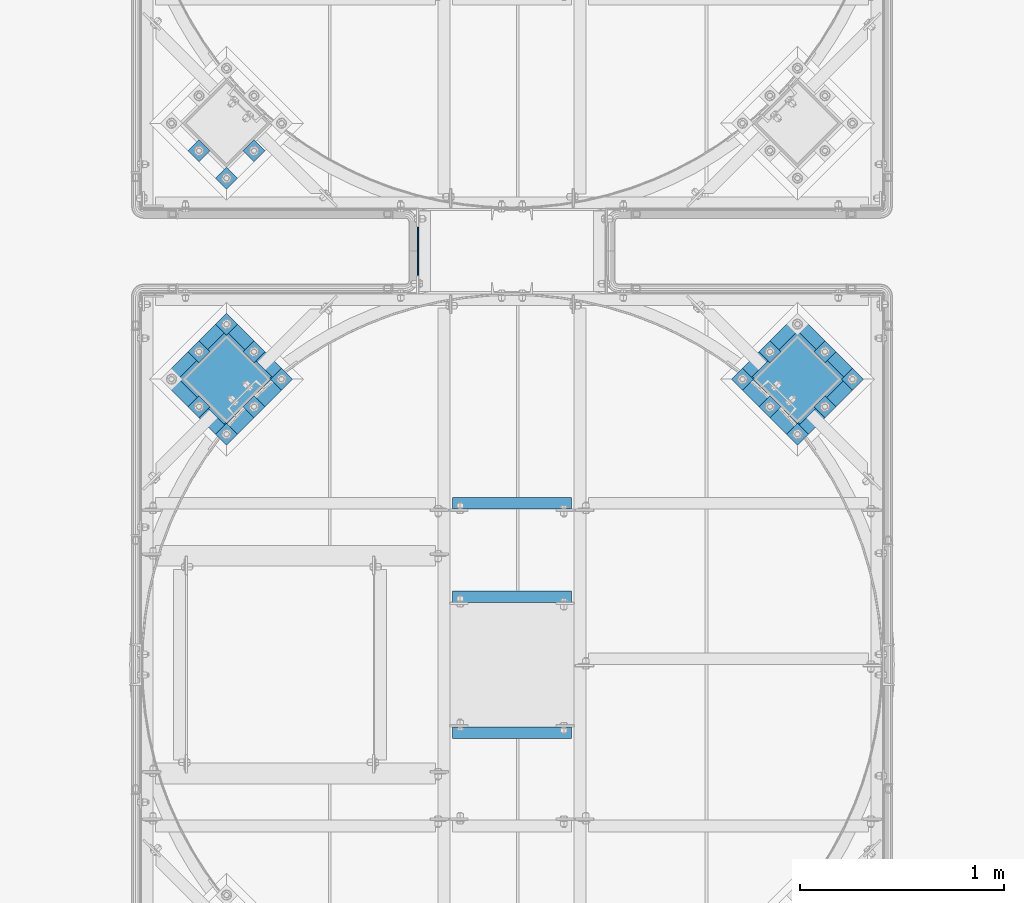
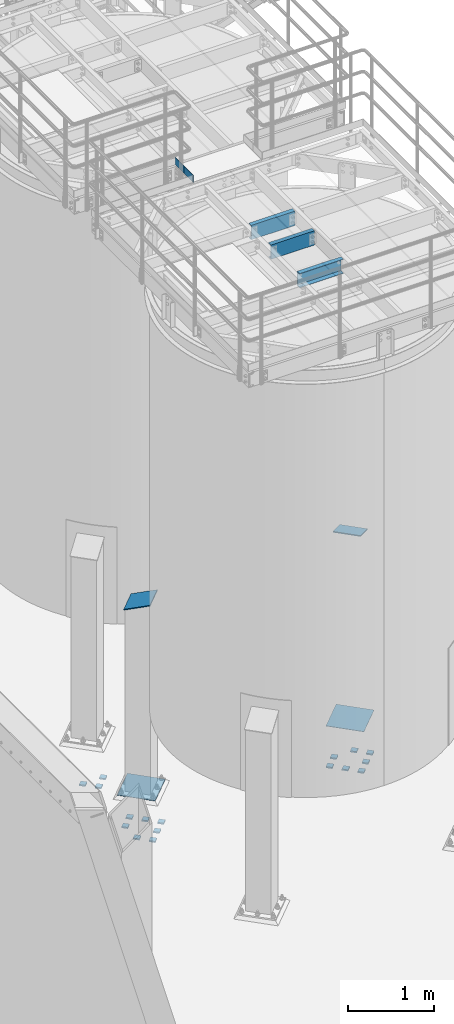
# One storey, part 1111 of 1876: 24 beams, 2 members, 10 elements without a shape of their own.
"""IFC2X3 building model written with IfcOpenShell, lengths in millimetres."""

from ifc_helpers import new_model, si_unit, frame, origin_with_axes, place, context, subcontext, project, spatial, faceted_brep, material, type_object, element, aggregate, save


model = new_model("IFC2X3")

# Units and contexts
model_context = context("Model", 3, precision=1e-05, world=origin_with_axes())
body_context = subcontext(model_context, "Body", "Model", "MODEL_VIEW")
ifc_project = project(units=[si_unit("LENGTHUNIT", "METRE", prefix="MILLI"), si_unit("AREAUNIT", "SQUARE_METRE"), si_unit("VOLUMEUNIT", "CUBIC_METRE"), si_unit("MASSUNIT", "GRAM", prefix="KILO"), si_unit("TIMEUNIT", "SECOND"), si_unit("PLANEANGLEUNIT", "RADIAN"), si_unit("SOLIDANGLEUNIT", "STERADIAN"), si_unit("THERMODYNAMICTEMPERATUREUNIT", "DEGREE_CELSIUS"), si_unit("LUMINOUSINTENSITYUNIT", "LUMEN")], contexts=[model_context])

# Site, building, storey
site_placement = place(None, origin_with_axes())
site = spatial("IfcSite", under=ifc_project, at=site_placement, CompositionType="ELEMENT")
building_placement = place(site_placement, origin_with_axes())
building = spatial("IfcBuilding", under=site, at=building_placement, Name="Undefined", CompositionType="ELEMENT")
storey_placement = place(building_placement, origin_with_axes())
storey = spatial("IfcBuildingStorey", under=building, at=storey_placement, Name="Undefined", CompositionType="ELEMENT", Elevation=0.0)

# Assembly, beam
assembly_1_placement = place(storey_placement, origin_with_axes())
assembly_1 = element("IfcElementAssembly", 1, at=assembly_1_placement, inside=storey, Name="HANDRAIL", AssemblyPlace="NOTDEFINED", PredefinedType="RIGID_FRAME")
ifc_material = material(Name="STEEL/A36")
beam_type_1 = type_object("IfcBeamType", PredefinedType="NOTDEFINED")
beam_1_placement = place(assembly_1_placement, frame((4721.22643150122, -11563.3144042962, 8080.375), z_axis=(0.0, 0.0, 1.0), x_axis=(0.0, 1.0, 0.0)))
beam_1 = element("IfcBeam", 2, at=beam_1_placement, type_object=beam_type_1, material=ifc_material, Name="PLATE", context=body_context, shape_type="Brep", body=[
    faceted_brep([(0.0, 3.17500000000018, -50.8000000000002), (0.0, 3.17500000000018, 50.8000000000002), (209.550048827514, 3.17500000000018, 50.8000000000002), (209.550048827514, 3.17500000000018, -50.8000000000002), (0.0, -3.17500000000018, 50.8000000000002), (209.550048827514, -3.17500000000018, 50.8000000000002), (0.0, -3.17500000000018, -50.8000000000002), (209.550048827514, -3.17500000000018, -50.8000000000002)], [[[0, 1, 2, 3]], [[1, 4, 5, 2]], [[4, 6, 7, 5]], [[6, 0, 3, 7]], [[5, 7, 3, 2]], [[6, 4, 1, 0]]]),
])
aggregate(assembly_1, [beam_1])

assembly_2_placement = place(storey_placement, origin_with_axes())
assembly_2 = element("IfcElementAssembly", 3, at=assembly_2_placement, inside=storey, Name="HANDRAIL", AssemblyPlace="NOTDEFINED", PredefinedType="RIGID_FRAME")
beam_2_placement = place(assembly_2_placement, frame((4721.22643150122, -11772.8644531238, 8080.375), z_axis=(0.0, 0.0, 1.0), x_axis=(0.0, 1.0, 0.0)))
beam_2 = element("IfcBeam", 4, at=beam_2_placement, type_object=beam_type_1, material=ifc_material, Name="PLATE", context=body_context, shape_type="Brep", body=[
    faceted_brep([(0.0, 3.17500000000018, -50.8000000000002), (0.0, 3.17500000000018, 50.8000000000002), (209.550048827514, 3.17500000000018, 50.8000000000002), (209.550048827514, 3.17500000000018, -50.8000000000002), (0.0, -3.17500000000018, 50.8000000000002), (209.550048827514, -3.17500000000018, 50.8000000000002), (0.0, -3.17500000000018, -50.8000000000002), (209.550048827514, -3.17500000000018, -50.8000000000002)], [[[0, 1, 2, 3]], [[1, 4, 5, 2]], [[4, 6, 7, 5]], [[6, 0, 3, 7]], [[5, 7, 3, 2]], [[6, 4, 1, 0]]]),
])
aggregate(assembly_2, [beam_2])

assembly_3_placement = place(storey_placement, origin_with_axes())
assembly_3 = element("IfcElementAssembly", 5, at=assembly_3_placement, inside=storey, Name="BEAM", AssemblyPlace="NOTDEFINED", PredefinedType="RIGID_FRAME")
beam_type_2 = type_object("IfcBeamType", Name="C8X11.5", PredefinedType="NOTDEFINED")
beam_3_placement = place(assembly_3_placement, frame((4876.8, -13255.5894287103, 7896.225), z_axis=(0.0, 0.0, -1.0), x_axis=(1.0, 0.0, 0.0)))
beam_3 = element("IfcBeam", 6, at=beam_3_placement, type_object=beam_type_2, material=ifc_material, Name="BEAM", ObjectType="C8X11.5", context=body_context, shape_type="Brep", body=[
    faceted_brep([(12.7014315012184, 28.5750000000007, -101.6), (12.7014315012184, 28.5750000000007, 101.6), (596.901431501219, 28.5750000000007, 101.6), (596.901431501219, 28.5750000000007, -101.6), (12.7014315012184, -28.5750000000007, 101.6), (596.901431501219, -28.5750000000007, 101.6), (12.7014315012184, -28.5750000000007, 96.8355949999996), (596.901431501219, -28.5750000000007, 96.8355949999996), (12.7014315012184, 22.2250000000004, 88.3723149999996), (596.901431501219, 22.2250000000004, 88.3723149999996), (12.7014315012184, 22.2250000000004, -88.3723149999996), (596.901431501219, 22.2250000000004, -88.3723149999996), (12.7014315012184, -28.5750000000007, -96.8355949999996), (596.901431501219, -28.5750000000007, -96.8355949999996), (12.7014315012184, -28.5750000000007, -101.6), (596.901431501219, -28.5750000000007, -101.6)], [[[0, 1, 2, 3]], [[1, 4, 5, 2]], [[4, 6, 7, 5]], [[6, 8, 9, 7]], [[8, 10, 11, 9]], [[10, 12, 13, 11]], [[12, 14, 15, 13]], [[14, 0, 3, 15]], [[5, 7, 9, 11, 13, 15, 3, 2]], [[14, 12, 10, 8, 6, 4, 1, 0]]]),
])
aggregate(assembly_3, [beam_3])

assembly_4_placement = place(storey_placement, origin_with_axes())
assembly_4 = element("IfcElementAssembly", 7, at=assembly_4_placement, inside=storey, Name="BEAM", AssemblyPlace="NOTDEFINED", PredefinedType="RIGID_FRAME")
beam_4_placement = place(assembly_4_placement, frame((4876.80143150122, -13922.3394287103, 7896.225), z_axis=(0.0, 0.0, 1.0), x_axis=(1.0, 0.0, 0.0)))
beam_4 = element("IfcBeam", 8, at=beam_4_placement, type_object=beam_type_2, material=ifc_material, Name="BEAM", ObjectType="C8X11.5", context=body_context, shape_type="Brep", body=[
    faceted_brep([(12.7000000000007, 28.5749999999998, -101.6), (12.7000000000007, 28.5749999999998, 101.6), (596.900000000001, 28.5750000000007, 101.6), (596.900000000001, 28.5750000000007, -101.6), (12.7000000000007, -28.5749999999998, 101.6), (596.900000000001, -28.5750000000007, 101.6), (12.7000000000007, -28.5749999999998, 96.8355949999996), (596.900000000001, -28.5750000000007, 96.8355949999996), (12.7000000000007, 22.2250000000004, 88.3723149999996), (596.900000000001, 22.2250000000004, 88.3723149999996), (12.7000000000007, 22.2250000000004, -88.3723149999996), (596.900000000001, 22.2250000000004, -88.3723149999996), (12.7000000000007, -28.5749999999998, -96.8355949999996), (596.900000000001, -28.5750000000007, -96.8355949999996), (12.7000000000007, -28.5749999999998, -101.6), (596.900000000001, -28.5750000000007, -101.6)], [[[0, 1, 2, 3]], [[1, 4, 5, 2]], [[4, 6, 7, 5]], [[6, 8, 9, 7]], [[8, 10, 11, 9]], [[10, 12, 13, 11]], [[12, 14, 15, 13]], [[14, 0, 3, 15]], [[5, 7, 9, 11, 13, 15, 3, 2]], [[14, 12, 10, 8, 6, 4, 1, 0]]]),
])
aggregate(assembly_4, [beam_4])

assembly_5_placement = place(storey_placement, origin_with_axes())
assembly_5 = element("IfcElementAssembly", 9, at=assembly_5_placement, inside=storey, Name="BEAM", AssemblyPlace="NOTDEFINED", PredefinedType="RIGID_FRAME")
beam_5_placement = place(assembly_5_placement, frame((4876.80143150122, -12798.3894042969, 7896.225), z_axis=(0.0, 0.0, -1.0), x_axis=(1.0, 0.0, 0.0)))
beam_5 = element("IfcBeam", 10, at=beam_5_placement, type_object=beam_type_2, material=ifc_material, Name="BEAM", ObjectType="C8X11.5", context=body_context, shape_type="Brep", body=[
    faceted_brep([(12.7000000000007, 28.5749999999998, -101.6), (12.7000000000007, 28.5749999999998, 101.6), (596.900000000001, 28.5750000000007, 101.6), (596.900000000001, 28.5750000000007, -101.6), (12.7000000000007, -28.5749999999998, 101.6), (596.900000000001, -28.5750000000007, 101.6), (12.7000000000007, -28.5749999999998, 96.8355949999996), (596.900000000001, -28.5750000000007, 96.8355949999996), (12.7000000000007, 22.2250000000004, 88.3723149999996), (596.900000000001, 22.2250000000004, 88.3723149999996), (12.7000000000007, 22.2250000000004, -88.3723149999996), (596.900000000001, 22.2250000000004, -88.3723149999996), (12.7000000000007, -28.5749999999998, -96.8355949999996), (596.900000000001, -28.5750000000007, -96.8355949999996), (12.7000000000007, -28.5749999999998, -101.6), (596.900000000001, -28.5750000000007, -101.6)], [[[0, 1, 2, 3]], [[1, 4, 5, 2]], [[4, 6, 7, 5]], [[6, 8, 9, 7]], [[8, 10, 11, 9]], [[10, 12, 13, 11]], [[12, 14, 15, 13]], [[14, 0, 3, 15]], [[5, 7, 9, 11, 13, 15, 3, 2]], [[14, 12, 10, 8, 6, 4, 1, 0]]]),
])
aggregate(assembly_5, [beam_5])

# Assembly, member
assembly_6_placement = place(storey_placement, origin_with_axes())
assembly_6 = element("IfcElementAssembly", 11, at=assembly_6_placement, inside=storey, Name="COLUMN", AssemblyPlace="NOTDEFINED", PredefinedType="RIGID_FRAME")
member_type = type_object("IfcMemberType", PredefinedType="NOTDEFINED")
member_1_placement = place(assembly_6_placement, frame((3889.24023857024, -12296.4977381371, 2749.16704824061), z_axis=(0.707106781186548, 0.707106781186547, 0.0), x_axis=(-0.664463024761457, 0.664463024761458, -0.342020141877214)))
member_1 = element("IfcMember", 12, at=member_1_placement, type_object=member_type, material=ifc_material, Name="PLATE", context=body_context, shape_type="Brep", body=[
    faceted_brep([(0.0, 6.35000000000042, -165.100000000026), (0.0, 6.35000000000042, 165.100000000029), (337.061384869998, 6.34999999999997, 165.099999999921), (337.061384869996, 6.34999999999997, -165.100000000135), (1.81898940354586e-12, -6.34999999999849, 165.100000000029), (337.061384869998, -6.3499999999994, 165.099999999921), (0.0, -6.34999999999894, -165.100000000026), (337.061384869998, -6.3499999999994, -165.100000000136)], [[[0, 1, 2, 3]], [[1, 4, 5, 2]], [[4, 6, 7, 5]], [[6, 0, 3, 7]], [[5, 7, 3, 2]], [[6, 4, 1, 0]]]),
])
aggregate(assembly_6, [member_1])

assembly_7_placement = place(storey_placement, origin_with_axes())
assembly_7 = element("IfcElementAssembly", 13, at=assembly_7_placement, inside=storey, Name="COLUMN", AssemblyPlace="NOTDEFINED", PredefinedType="RIGID_FRAME")
member_2_placement = place(assembly_7_placement, frame((6474.04753163907, -12296.552468352, 2749.16704814523), z_axis=(0.707106781186547, -0.707106781186548, 0.0), x_axis=(0.664463024761457, 0.664463024761457, -0.342020141877214)))
member_2 = element("IfcMember", 14, at=member_2_placement, type_object=member_type, material=ifc_material, Name="PLATE", context=body_context, shape_type="Brep", body=[
    faceted_brep([(0.0, 6.35000000000042, -165.100000000026), (0.0, 6.35000000000042, 165.100000000029), (337.061384869998, 6.34999999999997, 165.099999999921), (337.061384869996, 6.34999999999997, -165.100000000135), (1.81898940354586e-12, -6.34999999999849, 165.100000000029), (337.061384869998, -6.3499999999994, 165.099999999921), (0.0, -6.34999999999894, -165.100000000026), (337.061384869998, -6.3499999999994, -165.100000000136)], [[[0, 1, 2, 3]], [[1, 4, 5, 2]], [[4, 6, 7, 5]], [[6, 0, 3, 7]], [[5, 7, 3, 2]], [[6, 4, 1, 0]]]),
])
aggregate(assembly_7, [member_2])

# Assembly, beams
assembly_8_placement = place(storey_placement, origin_with_axes())
assembly_8 = element("IfcElementAssembly", 15, at=assembly_8_placement, inside=storey, Name="TEMPLATE", AssemblyPlace="NOTDEFINED", PredefinedType="RIGID_FRAME")
beam_type_3 = type_object("IfcBeamType", PredefinedType="NOTDEFINED")
beam_6_placement = place(assembly_8_placement, frame((6876.62334285216, -12163.3843407804, -542.925), z_axis=(-0.707106781186548, 0.707106781186547, 0.0), x_axis=(-0.707106781186547, -0.707106781186548, 0.0)))
beam_6 = element("IfcBeam", 16, at=beam_6_placement, type_object=beam_type_3, material=ifc_material, Name="PLATE", context=body_context, shape_type="Brep", body=[
    faceted_brep([(0.0, 9.52499999999998, -38.1000000000058), (-9.09494701772928e-13, 9.52499999999998, 38.1000000000076), (76.2000000000762, 9.52499999999998, 38.1000000000058), (76.2000000000762, 9.52499999999998, -38.1000000000058), (-9.09494701772928e-13, -9.52499999999998, 38.1000000000076), (76.2000000000762, -9.52499999999998, 38.1000000000058), (0.0, -9.52499999999998, -38.1000000000058), (76.2000000000762, -9.52499999999998, -38.1000000000058)], [[[0, 1, 2, 3]], [[1, 4, 5, 2]], [[4, 6, 7, 5]], [[6, 0, 3, 7]], [[5, 7, 3, 2]], [[6, 4, 1, 0]]]),
])
beam_7_placement = place(assembly_8_placement, frame((6741.91950103601, -12028.6804989642, -542.925), z_axis=(-0.707106781186548, 0.707106781186547, 0.0), x_axis=(-0.707106781186547, -0.707106781186548, 0.0)))
beam_7 = element("IfcBeam", 17, at=beam_7_placement, type_object=beam_type_3, material=ifc_material, Name="PLATE", context=body_context, shape_type="Brep", body=[
    faceted_brep([(0.0, 9.52499999999998, -38.1000000000058), (-9.09494701772928e-13, 9.52499999999998, 38.1000000000076), (76.2000000000762, 9.52499999999998, 38.1000000000058), (76.2000000000762, 9.52499999999998, -38.1000000000058), (-9.09494701772928e-13, -9.52499999999998, 38.1000000000076), (76.2000000000762, -9.52499999999998, 38.1000000000058), (0.0, -9.52499999999998, -38.1000000000058), (76.2000000000762, -9.52499999999998, -38.1000000000058)], [[[0, 1, 2, 3]], [[1, 4, 5, 2]], [[4, 6, 7, 5]], [[6, 0, 3, 7]], [[5, 7, 3, 2]], [[6, 4, 1, 0]]]),
])
beam_8_placement = place(assembly_8_placement, frame((6741.91950103601, -12298.0881825965, -542.925), z_axis=(-0.707106781186548, 0.707106781186547, 0.0), x_axis=(-0.707106781186547, -0.707106781186548, 0.0)))
beam_8 = element("IfcBeam", 18, at=beam_8_placement, type_object=beam_type_3, material=ifc_material, Name="PLATE", context=body_context, shape_type="Brep", body=[
    faceted_brep([(0.0, 9.52499999999998, -38.1000000000058), (-9.09494701772928e-13, 9.52499999999998, 38.1000000000076), (76.2000000000762, 9.52499999999998, 38.1000000000058), (76.2000000000762, 9.52499999999998, -38.1000000000058), (-9.09494701772928e-13, -9.52499999999998, 38.1000000000076), (76.2000000000762, -9.52499999999998, 38.1000000000058), (0.0, -9.52499999999998, -38.1000000000058), (76.2000000000762, -9.52499999999998, -38.1000000000058)], [[[0, 1, 2, 3]], [[1, 4, 5, 2]], [[4, 6, 7, 5]], [[6, 0, 3, 7]], [[5, 7, 3, 2]], [[6, 4, 1, 0]]]),
])
beam_9_placement = place(assembly_8_placement, frame((6472.5118174037, -12028.6804989642, -542.925), z_axis=(-0.707106781186548, 0.707106781186547, 0.0), x_axis=(-0.707106781186547, -0.707106781186548, 0.0)))
beam_9 = element("IfcBeam", 19, at=beam_9_placement, type_object=beam_type_3, material=ifc_material, Name="PLATE", context=body_context, shape_type="Brep", body=[
    faceted_brep([(0.0, 9.52499999999998, -38.1000000000058), (-9.09494701772928e-13, 9.52499999999998, 38.1000000000076), (76.2000000000762, 9.52499999999998, 38.1000000000058), (76.2000000000762, 9.52499999999998, -38.1000000000058), (-9.09494701772928e-13, -9.52499999999998, 38.1000000000076), (76.2000000000762, -9.52499999999998, 38.1000000000058), (0.0, -9.52499999999998, -38.1000000000058), (76.2000000000762, -9.52499999999998, -38.1000000000058)], [[[0, 1, 2, 3]], [[1, 4, 5, 2]], [[4, 6, 7, 5]], [[6, 0, 3, 7]], [[5, 7, 3, 2]], [[6, 4, 1, 0]]]),
])
beam_10_placement = place(assembly_8_placement, frame((6607.21565921985, -12432.7920244127, -542.925), z_axis=(-0.707106781186548, 0.707106781186547, 0.0), x_axis=(-0.707106781186547, -0.707106781186548, 0.0)))
beam_10 = element("IfcBeam", 20, at=beam_10_placement, type_object=beam_type_3, material=ifc_material, Name="PLATE", context=body_context, shape_type="Brep", body=[
    faceted_brep([(0.0, 9.52499999999998, -38.1000000000058), (-9.09494701772928e-13, 9.52499999999998, 38.1000000000076), (76.2000000000762, 9.52499999999998, 38.1000000000058), (76.2000000000762, 9.52499999999998, -38.1000000000058), (-9.09494701772928e-13, -9.52499999999998, 38.1000000000076), (76.2000000000762, -9.52499999999998, 38.1000000000058), (0.0, -9.52499999999998, -38.1000000000058), (76.2000000000762, -9.52499999999998, -38.1000000000058)], [[[0, 1, 2, 3]], [[1, 4, 5, 2]], [[4, 6, 7, 5]], [[6, 0, 3, 7]], [[5, 7, 3, 2]], [[6, 4, 1, 0]]]),
])
beam_11_placement = place(assembly_8_placement, frame((6472.5118174037, -12298.0881825965, -542.925), z_axis=(-0.707106781186548, 0.707106781186547, 0.0), x_axis=(-0.707106781186547, -0.707106781186548, 0.0)))
beam_11 = element("IfcBeam", 21, at=beam_11_placement, type_object=beam_type_3, material=ifc_material, Name="PLATE", context=body_context, shape_type="Brep", body=[
    faceted_brep([(0.0, 9.52499999999998, -38.1000000000058), (-9.09494701772928e-13, 9.52499999999998, 38.1000000000076), (76.2000000000762, 9.52499999999998, 38.1000000000058), (76.2000000000762, 9.52499999999998, -38.1000000000058), (-9.09494701772928e-13, -9.52499999999998, 38.1000000000076), (76.2000000000762, -9.52499999999998, 38.1000000000058), (0.0, -9.52499999999998, -38.1000000000058), (76.2000000000762, -9.52499999999998, -38.1000000000058)], [[[0, 1, 2, 3]], [[1, 4, 5, 2]], [[4, 6, 7, 5]], [[6, 0, 3, 7]], [[5, 7, 3, 2]], [[6, 4, 1, 0]]]),
])
beam_12_placement = place(assembly_8_placement, frame((6337.80797558755, -12163.3843407804, -542.925), z_axis=(-0.707106781186548, 0.707106781186547, 0.0), x_axis=(-0.707106781186547, -0.707106781186548, 0.0)))
beam_12 = element("IfcBeam", 22, at=beam_12_placement, type_object=beam_type_3, material=ifc_material, Name="PLATE", context=body_context, shape_type="Brep", body=[
    faceted_brep([(0.0, 9.52499999999998, -38.1000000000058), (-9.09494701772928e-13, 9.52499999999998, 38.1000000000076), (76.2000000000762, 9.52499999999998, 38.1000000000058), (76.2000000000762, 9.52499999999998, -38.1000000000058), (-9.09494701772928e-13, -9.52499999999998, 38.1000000000076), (76.2000000000762, -9.52499999999998, 38.1000000000058), (0.0, -9.52499999999998, -38.1000000000058), (76.2000000000762, -9.52499999999998, -38.1000000000058)], [[[0, 1, 2, 3]], [[1, 4, 5, 2]], [[4, 6, 7, 5]], [[6, 0, 3, 7]], [[5, 7, 3, 2]], [[6, 4, 1, 0]]]),
])

assembly_9_placement = place(storey_placement, origin_with_axes())
assembly_9 = element("IfcElementAssembly", 23, at=assembly_9_placement, inside=storey, Name="TEMPLATE", AssemblyPlace="NOTDEFINED", PredefinedType="RIGID_FRAME")
beam_13_placement = place(assembly_9_placement, frame((3944.57009868814, -11044.1408993808, -542.925), z_axis=(-0.707106781186548, 0.707106781186547, 0.0), x_axis=(-0.707106781186547, -0.707106781186548, 0.0)))
beam_13 = element("IfcBeam", 24, at=beam_13_placement, type_object=beam_type_3, material=ifc_material, Name="PLATE", context=body_context, shape_type="Brep", body=[
    faceted_brep([(0.0, 9.52499999999998, -38.1000000000058), (-9.09494701772928e-13, 9.52499999999998, 38.1000000000076), (76.2000000000762, 9.52499999999998, 38.1000000000058), (76.2000000000762, 9.52499999999998, -38.1000000000058), (-9.09494701772928e-13, -9.52499999999998, 38.1000000000076), (76.2000000000762, -9.52499999999998, 38.1000000000058), (0.0, -9.52499999999998, -38.1000000000058), (76.2000000000762, -9.52499999999998, -38.1000000000058)], [[[0, 1, 2, 3]], [[1, 4, 5, 2]], [[4, 6, 7, 5]], [[6, 0, 3, 7]], [[5, 7, 3, 2]], [[6, 4, 1, 0]]]),
])
beam_14_placement = place(assembly_9_placement, frame((3809.86625687199, -11178.8447411969, -542.925), z_axis=(-0.707106781186548, 0.707106781186547, 0.0), x_axis=(-0.707106781186547, -0.707106781186548, 0.0)))
beam_14 = element("IfcBeam", 25, at=beam_14_placement, type_object=beam_type_3, material=ifc_material, Name="PLATE", context=body_context, shape_type="Brep", body=[
    faceted_brep([(0.0, 9.52499999999998, -38.1000000000058), (-9.09494701772928e-13, 9.52499999999998, 38.1000000000076), (76.2000000000762, 9.52499999999998, 38.1000000000058), (76.2000000000762, 9.52499999999998, -38.1000000000058), (-9.09494701772928e-13, -9.52499999999998, 38.1000000000076), (76.2000000000762, -9.52499999999998, 38.1000000000058), (0.0, -9.52499999999998, -38.1000000000058), (76.2000000000762, -9.52499999999998, -38.1000000000058)], [[[0, 1, 2, 3]], [[1, 4, 5, 2]], [[4, 6, 7, 5]], [[6, 0, 3, 7]], [[5, 7, 3, 2]], [[6, 4, 1, 0]]]),
])
beam_15_placement = place(assembly_9_placement, frame((3675.16241505583, -11044.1408993808, -542.925), z_axis=(-0.707106781186548, 0.707106781186547, 0.0), x_axis=(-0.707106781186547, -0.707106781186548, 0.0)))
beam_15 = element("IfcBeam", 26, at=beam_15_placement, type_object=beam_type_3, material=ifc_material, Name="PLATE", context=body_context, shape_type="Brep", body=[
    faceted_brep([(0.0, 9.52499999999998, -38.1000000000058), (-9.09494701772928e-13, 9.52499999999998, 38.1000000000076), (76.2000000000762, 9.52499999999998, 38.1000000000058), (76.2000000000762, 9.52499999999998, -38.1000000000058), (-9.09494701772928e-13, -9.52499999999998, 38.1000000000076), (76.2000000000762, -9.52499999999998, 38.1000000000058), (0.0, -9.52499999999998, -38.1000000000058), (76.2000000000762, -9.52499999999998, -38.1000000000058)], [[[0, 1, 2, 3]], [[1, 4, 5, 2]], [[4, 6, 7, 5]], [[6, 0, 3, 7]], [[5, 7, 3, 2]], [[6, 4, 1, 0]]]),
])
aggregate(assembly_9, [beam_13, beam_14, beam_15])

assembly_10_placement = place(storey_placement, origin_with_axes())
assembly_10 = element("IfcElementAssembly", 27, at=assembly_10_placement, inside=storey, Name="TEMPLATE", AssemblyPlace="NOTDEFINED", PredefinedType="RIGID_FRAME")
beam_16_placement = place(assembly_10_placement, frame((4079.36133136081, -12163.3296105558, -542.925), z_axis=(-0.707106781186548, 0.707106781186547, 0.0), x_axis=(-0.707106781186547, -0.707106781186548, 0.0)))
beam_16 = element("IfcBeam", 28, at=beam_16_placement, type_object=beam_type_3, material=ifc_material, Name="PLATE", context=body_context, shape_type="Brep", body=[
    faceted_brep([(0.0, 9.52499999999998, -38.1000000000058), (-9.09494701772928e-13, 9.52499999999998, 38.1000000000076), (76.2000000000762, 9.52499999999998, 38.1000000000058), (76.2000000000762, 9.52499999999998, -38.1000000000058), (-9.09494701772928e-13, -9.52499999999998, 38.1000000000076), (76.2000000000762, -9.52499999999998, 38.1000000000058), (0.0, -9.52499999999998, -38.1000000000058), (76.2000000000762, -9.52499999999998, -38.1000000000058)], [[[0, 1, 2, 3]], [[1, 4, 5, 2]], [[4, 6, 7, 5]], [[6, 0, 3, 7]], [[5, 7, 3, 2]], [[6, 4, 1, 0]]]),
])
beam_17_placement = place(assembly_10_placement, frame((3944.65748954466, -12028.6257687396, -542.925), z_axis=(-0.707106781186548, 0.707106781186547, 0.0), x_axis=(-0.707106781186547, -0.707106781186548, 0.0)))
beam_17 = element("IfcBeam", 29, at=beam_17_placement, type_object=beam_type_3, material=ifc_material, Name="PLATE", context=body_context, shape_type="Brep", body=[
    faceted_brep([(0.0, 9.52499999999998, -38.1000000000058), (-9.09494701772928e-13, 9.52499999999998, 38.1000000000076), (76.2000000000762, 9.52499999999998, 38.1000000000058), (76.2000000000762, 9.52499999999998, -38.1000000000058), (-9.09494701772928e-13, -9.52499999999998, 38.1000000000076), (76.2000000000762, -9.52499999999998, 38.1000000000058), (0.0, -9.52499999999998, -38.1000000000058), (76.2000000000762, -9.52499999999998, -38.1000000000058)], [[[0, 1, 2, 3]], [[1, 4, 5, 2]], [[4, 6, 7, 5]], [[6, 0, 3, 7]], [[5, 7, 3, 2]], [[6, 4, 1, 0]]]),
])
beam_18_placement = place(assembly_10_placement, frame((3809.95364772851, -11893.9219269235, -542.925), z_axis=(-0.707106781186548, 0.707106781186547, 0.0), x_axis=(-0.707106781186547, -0.707106781186548, 0.0)))
beam_18 = element("IfcBeam", 30, at=beam_18_placement, type_object=beam_type_3, material=ifc_material, Name="PLATE", context=body_context, shape_type="Brep", body=[
    faceted_brep([(0.0, 9.52499999999998, -38.1000000000058), (-9.09494701772928e-13, 9.52499999999998, 38.1000000000076), (76.2000000000762, 9.52499999999998, 38.1000000000058), (76.2000000000762, 9.52499999999998, -38.1000000000058), (-9.09494701772928e-13, -9.52499999999998, 38.1000000000076), (76.2000000000762, -9.52499999999998, 38.1000000000058), (0.0, -9.52499999999998, -38.1000000000058), (76.2000000000762, -9.52499999999998, -38.1000000000058)], [[[0, 1, 2, 3]], [[1, 4, 5, 2]], [[4, 6, 7, 5]], [[6, 0, 3, 7]], [[5, 7, 3, 2]], [[6, 4, 1, 0]]]),
])
beam_19_placement = place(assembly_10_placement, frame((3944.65748954466, -12298.0334523719, -542.925), z_axis=(-0.707106781186548, 0.707106781186547, 0.0), x_axis=(-0.707106781186547, -0.707106781186548, 0.0)))
beam_19 = element("IfcBeam", 31, at=beam_19_placement, type_object=beam_type_3, material=ifc_material, Name="PLATE", context=body_context, shape_type="Brep", body=[
    faceted_brep([(0.0, 9.52499999999998, -38.1000000000058), (-9.09494701772928e-13, 9.52499999999998, 38.1000000000076), (76.2000000000762, 9.52499999999998, 38.1000000000058), (76.2000000000762, 9.52499999999998, -38.1000000000058), (-9.09494701772928e-13, -9.52499999999998, 38.1000000000076), (76.2000000000762, -9.52499999999998, 38.1000000000058), (0.0, -9.52499999999998, -38.1000000000058), (76.2000000000762, -9.52499999999998, -38.1000000000058)], [[[0, 1, 2, 3]], [[1, 4, 5, 2]], [[4, 6, 7, 5]], [[6, 0, 3, 7]], [[5, 7, 3, 2]], [[6, 4, 1, 0]]]),
])
beam_20_placement = place(assembly_10_placement, frame((3675.24980591236, -12028.6257687396, -542.925), z_axis=(-0.707106781186548, 0.707106781186547, 0.0), x_axis=(-0.707106781186547, -0.707106781186548, 0.0)))
beam_20 = element("IfcBeam", 32, at=beam_20_placement, type_object=beam_type_3, material=ifc_material, Name="PLATE", context=body_context, shape_type="Brep", body=[
    faceted_brep([(0.0, 9.52499999999998, -38.1000000000058), (-9.09494701772928e-13, 9.52499999999998, 38.1000000000076), (76.2000000000762, 9.52499999999998, 38.1000000000058), (76.2000000000762, 9.52499999999998, -38.1000000000058), (-9.09494701772928e-13, -9.52499999999998, 38.1000000000076), (76.2000000000762, -9.52499999999998, 38.1000000000058), (0.0, -9.52499999999998, -38.1000000000058), (76.2000000000762, -9.52499999999998, -38.1000000000058)], [[[0, 1, 2, 3]], [[1, 4, 5, 2]], [[4, 6, 7, 5]], [[6, 0, 3, 7]], [[5, 7, 3, 2]], [[6, 4, 1, 0]]]),
])
beam_21_placement = place(assembly_10_placement, frame((3809.95364772851, -12432.7372941881, -542.925), z_axis=(-0.707106781186548, 0.707106781186547, 0.0), x_axis=(-0.707106781186547, -0.707106781186548, 0.0)))
beam_21 = element("IfcBeam", 33, at=beam_21_placement, type_object=beam_type_3, material=ifc_material, Name="PLATE", context=body_context, shape_type="Brep", body=[
    faceted_brep([(0.0, 9.52499999999998, -38.1000000000058), (-9.09494701772928e-13, 9.52499999999998, 38.1000000000076), (76.2000000000762, 9.52499999999998, 38.1000000000058), (76.2000000000762, 9.52499999999998, -38.1000000000058), (-9.09494701772928e-13, -9.52499999999998, 38.1000000000076), (76.2000000000762, -9.52499999999998, 38.1000000000058), (0.0, -9.52499999999998, -38.1000000000058), (76.2000000000762, -9.52499999999998, -38.1000000000058)], [[[0, 1, 2, 3]], [[1, 4, 5, 2]], [[4, 6, 7, 5]], [[6, 0, 3, 7]], [[5, 7, 3, 2]], [[6, 4, 1, 0]]]),
])
beam_22_placement = place(assembly_10_placement, frame((3675.24980591236, -12298.0334523719, -542.925), z_axis=(-0.707106781186548, 0.707106781186547, 0.0), x_axis=(-0.707106781186547, -0.707106781186548, 0.0)))
beam_22 = element("IfcBeam", 34, at=beam_22_placement, type_object=beam_type_3, material=ifc_material, Name="PLATE", context=body_context, shape_type="Brep", body=[
    faceted_brep([(0.0, 9.52499999999998, -38.1000000000058), (-9.09494701772928e-13, 9.52499999999998, 38.1000000000076), (76.2000000000762, 9.52499999999998, 38.1000000000058), (76.2000000000762, 9.52499999999998, -38.1000000000058), (-9.09494701772928e-13, -9.52499999999998, 38.1000000000076), (76.2000000000762, -9.52499999999998, 38.1000000000058), (0.0, -9.52499999999998, -38.1000000000058), (76.2000000000762, -9.52499999999998, -38.1000000000058)], [[[0, 1, 2, 3]], [[1, 4, 5, 2]], [[4, 6, 7, 5]], [[6, 0, 3, 7]], [[5, 7, 3, 2]], [[6, 4, 1, 0]]]),
])

# Beam
beam_type_4 = type_object("IfcBeamType", PredefinedType="NOTDEFINED")
beam_23_placement = place(assembly_8_placement, frame((6741.91950103587, -12028.6804989641, 40.4815), z_axis=(0.707106781186547, -0.707106781186548, 0.0), x_axis=(-0.707106781186547, -0.707106781186548, 0.0)))
beam_23 = element("IfcBeam", 35, at=beam_23_placement, type_object=beam_type_4, material=ifc_material, Name="TEMPLATE", context=body_context, shape_type="Brep", body=[
    faceted_brep([(9.09494701772928e-13, 2.3815, -228.600000000035), (-9.09494701772928e-13, 2.3815, 228.60000000004), (457.200000000363, 2.3815, 228.60000000004), (457.200000000362, 2.3815, -228.600000000037), (-9.09494701772928e-13, -2.3815, 228.60000000004), (457.200000000363, -2.3815, 228.60000000004), (9.09494701772928e-13, -2.3815, -228.600000000035), (457.200000000362, -2.3815, -228.600000000037)], [[[0, 1, 2, 3]], [[1, 4, 5, 2]], [[4, 6, 7, 5]], [[6, 0, 3, 7]], [[5, 7, 3, 2]], [[6, 4, 1, 0]]]),
])

aggregate(assembly_8, [beam_6, beam_7, beam_8, beam_9, beam_10, beam_11, beam_12, beam_23])

beam_24_placement = place(assembly_10_placement, frame((3944.65748954452, -12028.6257687395, 40.4815), z_axis=(0.707106781186547, -0.707106781186548, 0.0), x_axis=(-0.707106781186547, -0.707106781186548, 0.0)))
beam_24 = element("IfcBeam", 36, at=beam_24_placement, type_object=beam_type_4, material=ifc_material, Name="TEMPLATE", context=body_context, shape_type="Brep", body=[
    faceted_brep([(9.09494701772928e-13, 2.3815, -228.600000000035), (-9.09494701772928e-13, 2.3815, 228.60000000004), (457.200000000363, 2.3815, 228.60000000004), (457.200000000362, 2.3815, -228.600000000037), (-9.09494701772928e-13, -2.3815, 228.60000000004), (457.200000000363, -2.3815, 228.60000000004), (9.09494701772928e-13, -2.3815, -228.600000000035), (457.200000000362, -2.3815, -228.600000000037)], [[[0, 1, 2, 3]], [[1, 4, 5, 2]], [[4, 6, 7, 5]], [[6, 0, 3, 7]], [[5, 7, 3, 2]], [[6, 4, 1, 0]]]),
])

aggregate(assembly_10, [beam_16, beam_17, beam_18, beam_19, beam_20, beam_21, beam_22, beam_24])

save(model, "model.ifc")
